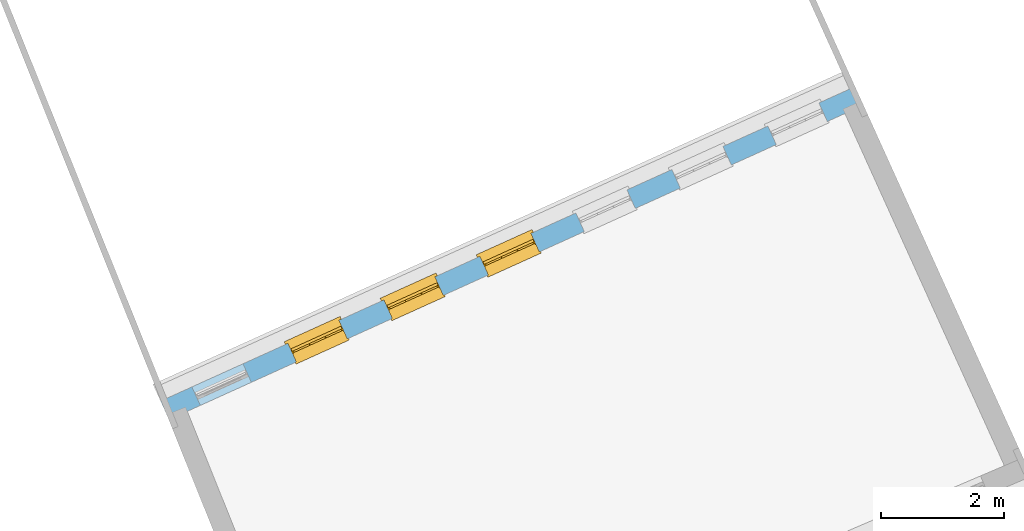
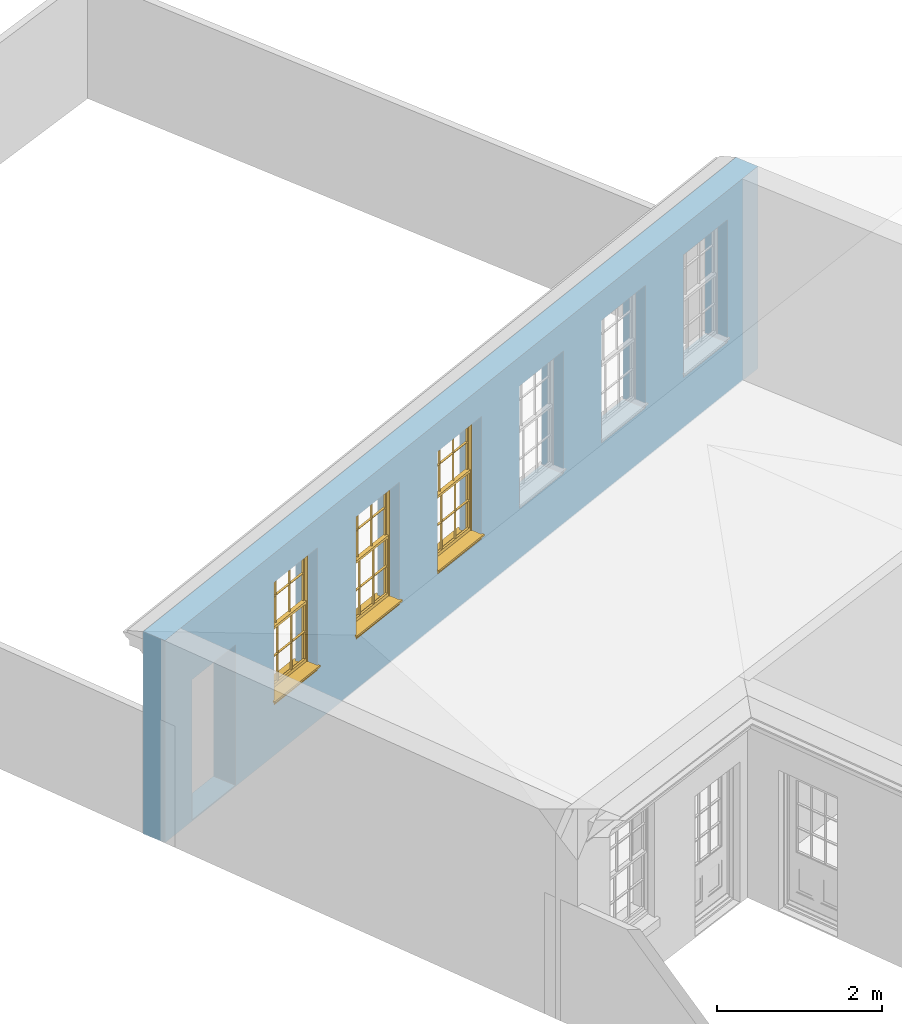
# One storey, part 16 of 19: 3 windows, 7 openings, plus 1 element that does not belong to this part.
"""IFC2X3 building model written with IfcOpenShell, lengths in metres."""

import ifcopenshell
import ifcopenshell.guid

model = None  # the IFC model being written
_history = None  # IfcOwnerHistory: only IFC2X3 demands one
_inside = {}  # id of a spatial element -> (the spatial element, [elements in it])
_under = {}  # id of a project, library or spatial element -> (it, [spatial elements below it])
_declared = {}  # id of a project -> (the project, [libraries it declares])
_typed = {}  # id of a type object -> (the type object, [elements of that type])
_made_of = {}  # id of a material, layer set ... -> (it, [elements and type objects made of it])


def new_model(schema):
    """Start an empty IFC model of exactly this schema.

    Asked for "IFC4X3", IfcOpenShell would pick the latest addendum, in which some entities
    have other attributes; the version numbers below select the first issue.
    IFC2X3 requires an IfcOwnerHistory on every rooted entity: one is made here for all.
    """
    global model, _history
    if schema == "IFC4X3":
        model = ifcopenshell.file(schema_version=(4, 3, 0, 0))
    else:
        model = ifcopenshell.file(schema=schema)
    _inside.clear()
    _under.clear()
    _declared.clear()
    _typed.clear()
    _made_of.clear()
    _history = None
    if model.schema == "IFC2X3":
        org = make("IfcOrganization", Name="unknown")
        user = make(
            "IfcPersonAndOrganization",
            ThePerson=make("IfcPerson", FamilyName="unknown"),
            TheOrganization=org,
        )
        app = make(
            "IfcApplication",
            ApplicationDeveloper=org,
            Version="unknown",
            ApplicationFullName="unknown",
            ApplicationIdentifier="unknown",
        )
        _history = make(
            "IfcOwnerHistory",
            OwningUser=user,
            OwningApplication=app,
            ChangeAction="ADDED",
            CreationDate=0,
        )
    return model


def make(cls, **values):
    """One entity of the class cls with the attributes given. An attribute that is None is left unset."""
    return model.create_entity(
        cls, **{name: value for name, value in values.items() if value is not None}
    )


def rooted(cls, **values):
    """An entity with a GlobalId (a new one), such as an element, a storey or a relation."""
    return make(cls, GlobalId=ifcopenshell.guid.new(), OwnerHistory=_history, **values)


def si_unit(unit_type, name, prefix=None):
    """IfcSIUnit, for example si_unit("LENGTHUNIT", "METRE", prefix="MILLI")."""
    return make("IfcSIUnit", UnitType=unit_type, Prefix=prefix, Name=name)


def assignment(units):
    """IfcUnitAssignment: the units of a project."""
    return None if units is None else make("IfcUnitAssignment", Units=units)


def point(xyz):
    """IfcCartesianPoint."""
    return None if xyz is None else make("IfcCartesianPoint", Coordinates=xyz)


def direction(xyz):
    """IfcDirection."""
    return None if xyz is None else make("IfcDirection", DirectionRatios=xyz)


def frame(location, z_axis=None, x_axis=None):
    """IfcAxis2Placement3D, a coordinate frame: its origin and axes. An axis left out is left unset."""
    return make(
        "IfcAxis2Placement3D",
        Location=point(location),
        Axis=direction(z_axis),
        RefDirection=direction(x_axis),
    )


def origin():
    """The frame at (0, 0, 0) with its axes left unset."""
    return frame((0.0, 0.0, 0.0))


def place(relative_to, where):
    """IfcLocalPlacement: puts the frame where relative to a parent placement (None: the world)."""
    return make(
        "IfcLocalPlacement", PlacementRelTo=relative_to, RelativePlacement=where
    )


def context(
    kind, dimensions, precision=None, world=None, true_north=None, identifier=None
):
    """IfcGeometricRepresentationContext, for example the 3D "Model" context."""
    return make(
        "IfcGeometricRepresentationContext",
        ContextIdentifier=identifier,
        ContextType=kind,
        CoordinateSpaceDimension=dimensions,
        Precision=precision,
        WorldCoordinateSystem=world,
        TrueNorth=true_north,
    )


def subcontext(parent, identifier, kind, view, scale=None):
    """IfcGeometricRepresentationSubContext, for example "Body" below "Model"."""
    return make(
        "IfcGeometricRepresentationSubContext",
        ContextIdentifier=identifier,
        ContextType=kind,
        ParentContext=parent,
        TargetScale=scale,
        TargetView=view,
    )


def project(units=None, contexts=None):
    """IfcProject with its units and contexts."""
    return rooted(
        "IfcProject",
        Name="project",
        RepresentationContexts=contexts,
        UnitsInContext=assignment(units),
    )


def spatial(cls, under=None, at=None, **own):
    """A site, building, storey or space (cls), placed at a placement, below another one or the project."""
    s = rooted(cls, ObjectPlacement=at, **own)
    if under is not None:
        _under.setdefault(under.id(), (under, []))[1].append(s)
    return s


def polyline(points):
    """IfcPolyline through the points."""
    return make("IfcPolyline", Points=[point(p) for p in points])


def outline(outer, holes=None, kind="AREA"):
    """IfcArbitraryClosedProfileDef: a profile drawn as a closed curve; with holes, ...WithVoids."""
    if holes is None:
        return make("IfcArbitraryClosedProfileDef", ProfileType=kind, OuterCurve=outer)
    return make(
        "IfcArbitraryProfileDefWithVoids",
        ProfileType=kind,
        OuterCurve=outer,
        InnerCurves=holes,
    )


def extrude(swept, where, along, depth):
    """IfcExtrudedAreaSolid: the profile swept, set in the frame where, extruded along a direction by depth."""
    return make(
        "IfcExtrudedAreaSolid",
        SweptArea=swept,
        Position=where,
        ExtrudedDirection=direction(along),
        Depth=depth,
    )


def faces_of(points, faces, orient=None, outer=None):
    """IfcFace entities. A face is a list of loops; a loop is a list of indices into points, from 0.

    orient and outer hold one flag for each loop. By default every Orientation is true, the
    first loop of a face is its IfcFaceOuterBound and the others are IfcFaceBound.
    """
    made = []
    for i, loops in enumerate(faces):
        bounds = []
        for j, loop in enumerate(loops):
            is_outer = j == 0 if outer is None else outer[i][j]
            bounds.append(
                make(
                    "IfcFaceOuterBound" if is_outer else "IfcFaceBound",
                    Bound=make("IfcPolyLoop", Polygon=[points[k] for k in loop]),
                    Orientation=True if orient is None else orient[i][j],
                )
            )
        made.append(make("IfcFace", Bounds=bounds))
    return made


def faceted_brep(points, faces, orient=None, outer=None, voids=None):
    """IfcFacetedBrep: a solid bounded by flat faces; with voids (closed shells), ...WithVoids."""
    shared = [point(p) for p in points]
    hull = make("IfcClosedShell", CfsFaces=faces_of(shared, faces, orient, outer))
    if voids is None:
        return make("IfcFacetedBrep", Outer=hull)
    return make(
        "IfcFacetedBrepWithVoids",
        Outer=hull,
        Voids=[
            make(cls, CfsFaces=faces_of(shared, fs, o, b)) for cls, fs, o, b in voids
        ],
    )


def shape(context_of_items, identifier, shape_type, items):
    """IfcShapeRepresentation: the items that make up one representation, for example the "Body"."""
    return make(
        "IfcShapeRepresentation",
        ContextOfItems=context_of_items,
        RepresentationIdentifier=identifier,
        RepresentationType=shape_type,
        Items=items,
    )


def material(Name=None, Category=None):
    """IfcMaterial."""
    return make("IfcMaterial", Name=Name, Category=Category)


def layer(
    of_material, thickness, ventilated=None, Name=None, Category=None, Priority=None
):
    """IfcMaterialLayer: one layer of a wall or slab, of a material (None: an air gap)."""
    return make(
        "IfcMaterialLayer",
        Material=of_material,
        LayerThickness=thickness,
        IsVentilated=ventilated,
        Name=Name,
        Category=Category,
        Priority=Priority,
    )


def layer_set(layers, Name=None):
    """IfcMaterialLayerSet."""
    return make("IfcMaterialLayerSet", MaterialLayers=layers, LayerSetName=Name)


def layer_usage(for_layer_set, set_direction, sense, offset, extent=None):
    """IfcMaterialLayerSetUsage: how a layer set lies in its element."""
    return make(
        "IfcMaterialLayerSetUsage",
        ForLayerSet=for_layer_set,
        LayerSetDirection=set_direction,
        DirectionSense=sense,
        OffsetFromReferenceLine=offset,
        ReferenceExtent=extent,
    )


def made_of(thing, what):
    """Note that an element or type object is made of a material, layer set ...; save() writes the relation."""
    if what is not None:
        _made_of.setdefault(what.id(), (what, []))[1].append(thing)
    return thing


def element(
    cls,
    number,
    at=None,
    inside=None,
    cuts=None,
    type_object=None,
    material=None,
    context=None,
    identifier="Body",
    shape_type=None,
    held_by="IfcProductDefinitionShape",
    body=None,
    shapes=None,
    **own,
):
    """One element of the class cls, such as IfcWall. Its Tag is "e" and its number.

    at: its placement. inside: the storey or other place that contains it. cuts: it is an
    opening in that element (IfcRelVoidsElement). A single representation is given by context,
    identifier, shape_type and body (its items); several are given by shapes. held_by: the class
    of the entity that holds the representations. save() writes the other relations.
    """
    e = rooted(cls, Tag="e%d" % number, ObjectPlacement=at, **own)
    if body is not None:
        shapes = [shape(context, identifier, shape_type, body)]
    if shapes is not None:
        e.Representation = make(held_by, Representations=shapes)
    if inside is not None:
        _inside.setdefault(inside.id(), (inside, []))[1].append(e)
    if cuts is not None:
        rooted(
            "IfcRelVoidsElement", RelatingBuildingElement=cuts, RelatedOpeningElement=e
        )
    if type_object is not None:
        _typed.setdefault(type_object.id(), (type_object, []))[1].append(e)
    return made_of(e, material)


def fill(opening, filler):
    """IfcRelFillsElement: the door or window that sits in an opening."""
    return rooted(
        "IfcRelFillsElement",
        RelatingOpeningElement=opening,
        RelatedBuildingElement=filler,
    )


def aggregate(whole, parts):
    """IfcRelAggregates: a whole, such as a stair, and the parts it consists of."""
    return rooted("IfcRelAggregates", RelatingObject=whole, RelatedObjects=parts)


def save(model, path):
    """Write the relations noted so far, then the file.

    IfcRelAggregates (storeys below a building ...), IfcRelContainedInSpatialStructure (elements
    in a storey), IfcRelDefinesByType, IfcRelAssociatesMaterial and IfcRelDeclares: one each for
    every whole, place, type object, material and project.
    """
    for whole, parts in _under.values():
        aggregate(whole, parts)
    for where, things in _inside.values():
        rooted(
            "IfcRelContainedInSpatialStructure",
            RelatedElements=things,
            RelatingStructure=where,
        )
    for kind, things in _typed.values():
        rooted("IfcRelDefinesByType", RelatedObjects=things, RelatingType=kind)
    for what, things in _made_of.values():
        rooted("IfcRelAssociatesMaterial", RelatedObjects=things, RelatingMaterial=what)
    for by, libraries in _declared.values():
        rooted("IfcRelDeclares", RelatingContext=by, RelatedDefinitions=libraries)
    model.write(path)


model = new_model("IFC2X3")

# Units and contexts
model_context = context("Model", 3, world=origin())
body_context = subcontext(model_context, "Body", "Model", "MODEL_VIEW")
ifc_project = project(units=[si_unit("PLANEANGLEUNIT", "RADIAN"), si_unit("MASSUNIT", "GRAM", prefix="KILO"), si_unit("FORCEUNIT", "NEWTON", prefix="KILO"), si_unit("LENGTHUNIT", "METRE")], contexts=[model_context])

# Site, building, storey
site_placement = place(None, origin())
site = spatial("IfcSite", under=ifc_project, at=site_placement, CompositionType="ELEMENT")
building_placement = place(None, origin())
building = spatial("IfcBuilding", under=site, at=building_placement, Name="Building plot-0", CompositionType="ELEMENT")
storey_placement = place(None, origin())
storey = spatial("IfcBuildingStorey", under=building, at=storey_placement, Name="Floor 0", CompositionType="ELEMENT", Elevation=0.0)

# Wall, openings, windows
ifc_material = material(Name="Masonry")
ifc_layer = layer(ifc_material, 0.33, ventilated=False)
ifc_layer_set = layer_set([ifc_layer], Name="My Wall")
ifc_layer_usage = layer_usage(ifc_layer_set, "AXIS2", "NEGATIVE", 0.08)
wall_placement = place(storey_placement, origin())
wall = element("IfcWallStandardCase", 1, at=wall_placement, inside=storey, material=ifc_layer_usage, Name="exterior", context=body_context, shape_type="SweptSolid", body=[
    extrude(outline(polyline([(21.5007118437475, 40.3889268355029), (21.3645733407012, 40.6895367288669), (10.0949852202286, 35.5858295970064), (10.2311237232749, 35.2852197036424), (21.5007118437475, 40.3889268355029)])), origin(), (0.0, 0.0, 1.0), 3.0),
])
opening_1_placement = place(storey_placement, frame((0.0, 0.0, 0.75)))
element("IfcOpeningElement", 2, at=opening_1_placement, cuts=wall, Name="Opening", ObjectType="Opening", context=body_context, shape_type="SweptSolid", body=[
    extrude(outline(polyline([(20.7788788084242, 40.4242907119302), (19.9499242539963, 40.048878476257), (20.0860627570426, 39.748268582893), (20.9150173114706, 40.1236808185662), (20.7788788084242, 40.4242907119302)])), origin(), (0.0, 0.0, 1.0), 1.82),
])
opening_2_placement = place(storey_placement, frame((0.0, 0.0, 0.75)))
element("IfcOpeningElement", 3, at=opening_2_placement, cuts=wall, Name="Opening", ObjectType="Opening", context=body_context, shape_type="SweptSolid", body=[
    extrude(outline(polyline([(19.2211729973563, 39.7188457415993), (18.3922184429283, 39.3434335059261), (18.5283569459746, 39.0428236125621), (19.3573115004026, 39.4182358482353), (19.2211729973563, 39.7188457415993)])), origin(), (0.0, 0.0, 1.0), 1.82),
])
opening_3_placement = place(storey_placement, frame((0.0, 0.0, 0.75)))
element("IfcOpeningElement", 4, at=opening_3_placement, cuts=wall, Name="Opening", ObjectType="Opening", context=body_context, shape_type="SweptSolid", body=[
    extrude(outline(polyline([(17.6634671862884, 39.0134007712684), (16.8345126318604, 38.6379885355952), (16.9706511349067, 38.3373786422312), (17.7996056893347, 38.7127908779044), (17.6634671862884, 39.0134007712684)])), origin(), (0.0, 0.0, 1.0), 1.82),
])
opening_4_placement = place(storey_placement, frame((0.0, 0.0, 0.75)))
opening_4 = element("IfcOpeningElement", 5, at=opening_4_placement, cuts=wall, Name="Opening", ObjectType="Opening", context=body_context, shape_type="SweptSolid", body=[
    extrude(outline(polyline([(16.1057613752204, 38.3079558009375), (15.2768068207924, 37.9325435652643), (15.4129453238388, 37.6319336719003), (16.2418998782667, 38.0073459075735), (16.1057613752204, 38.3079558009375)])), origin(), (0.0, 0.0, 1.0), 1.82),
])
opening_5_placement = place(storey_placement, frame((0.0, 0.0, 0.75)))
opening_5 = element("IfcOpeningElement", 6, at=opening_5_placement, cuts=wall, Name="Opening", ObjectType="Opening", context=body_context, shape_type="SweptSolid", body=[
    extrude(outline(polyline([(14.5480555641525, 37.6025108306066), (13.7191010097245, 37.2270985949334), (13.8552395127708, 36.9264887015694), (14.6841940671988, 37.3019009372426), (14.5480555641525, 37.6025108306066)])), origin(), (0.0, 0.0, 1.0), 1.82),
])
opening_6_placement = place(storey_placement, frame((0.0, 0.0, 0.75)))
opening_6 = element("IfcOpeningElement", 7, at=opening_6_placement, cuts=wall, Name="Opening", ObjectType="Opening", context=body_context, shape_type="SweptSolid", body=[
    extrude(outline(polyline([(12.9903497530845, 36.8970658602757), (12.1613951986565, 36.5216536246025), (12.2975337017029, 36.2210437312385), (13.1264882561308, 36.5964559669117), (12.9903497530845, 36.8970658602757)])), origin(), (0.0, 0.0, 1.0), 1.82),
])
opening_7_placement = place(storey_placement, frame((0.0, 0.0, 0.02)))
element("IfcOpeningElement", 8, at=opening_7_placement, cuts=wall, Name="Opening", ObjectType="Opening", context=body_context, shape_type="SweptSolid", body=[
    extrude(outline(polyline([(11.4326439420166, 36.1916208899448), (10.6036893875886, 35.8162086542716), (10.7398278906349, 35.5155987609077), (11.5687824450629, 35.8910109965808), (11.4326439420166, 36.1916208899448)])), origin(), (0.0, 0.0, 1.0), 2.08),
])
window_1_placement = place(storey_placement, frame((16.2088966048009, 38.0802210332375, 0.75), z_axis=(0.0, 0.0, 1.0), x_axis=(-0.82895455442797, -0.37541223567316, 0.0)))
window_1 = element("IfcWindow", 9, at=window_1_placement, inside=storey, Name="bedroom window", OverallHeight=1.82, OverallWidth=0.91, context=body_context, shape_type="Brep", held_by="IfcProductRepresentation", body=[
    faceted_brep([(0.033125, -0.105, 0.975209), (0.01, -0.105, 0.975209), (0.033125, -0.105, 1.376042), (0.876875, -0.105, 0.975209), (0.876875, -0.105, 1.376042), (0.9, -0.105, 0.975209), (0.876875, -0.105, 1.386042), (0.876875, -0.105, 1.786875), (0.9, -0.105, 1.81), (0.033125, -0.105, 1.786875), (0.033125, -0.105, 1.386042), (0.01, -0.105, 1.81), (0.876875, -0.135, 1.376042), (0.876875, -0.135, 0.975209), (0.9, -0.135, 0.937083), (0.033125, -0.135, 1.786875), (0.01, -0.135, 1.81), (0.033125, -0.135, 1.386042), (0.01, -0.135, 0.937083), (0.033125, -0.135, 0.975209), (0.033125, -0.135, 1.376042), (0.876875, -0.135, 1.786875), (0.876875, -0.135, 1.386042), (0.9, -0.135, 1.81), (0.033125, -0.105, 0.937083), (0.01, -0.105, 0.937083), (0.033125, -0.105, 0.53625), (0.876875, -0.105, 0.937083), (0.876875, -0.105, 0.53625), (0.9, -0.105, 0.937083), (0.876875, -0.105, 0.52625), (0.876875, -0.105, 0.125417), (0.9, -0.105, 0.077167), (0.033125, -0.105, 0.125417), (0.033125, -0.105, 0.52625), (0.01, -0.105, 0.077167), (-0.0425, -0.25, 0.01), (-0.0425, -0.3, 0.001667), (0.0, -0.25, 0.01), (0.9525, -0.25, 0.01), (0.91, -0.25, 0.01), (0.9525, -0.3, 0.001667), (-0.02, 0.08, 0.077167), (0.0, 0.08, 0.077167), (-0.02, 0.11, 0.077167), (0.0, -0.06, 0.077167), (0.01, -0.06, 0.077167), (0.91, -0.06, 0.077167), (0.91, 0.08, 0.077167), (0.9, -0.06, 0.077167), (0.93, 0.08, 0.077167), (0.93, 0.11, 0.077167), (0.01, -0.075, 0.975209), (0.9, -0.075, 0.975209), (0.876875, -0.075, 0.125417), (0.876875, -0.075, 0.52625), (0.9, -0.075, 0.077167), (0.876875, -0.075, 0.53625), (0.876875, -0.075, 0.937083), (0.033125, -0.075, 0.125417), (0.01, -0.075, 0.077167), (0.033125, -0.075, 0.52625), (0.033125, -0.075, 0.937083), (0.033125, -0.075, 0.53625), (-0.02, 0.08, 0.052167), (-0.02, 0.11, 0.052167), (0.93, 0.11, 0.052167), (0.93, 0.08, 0.052167), (0.91, 0.08, 0.052167), (0.0, 0.08, 0.052167), (0.91, -0.15, 0.026667), (0.0, -0.15, 0.026667), (-0.0425, -0.3, -0.123333), (0.9525, -0.3, -0.123333), (-0.0425, -0.25, -0.123333), (0.9525, -0.25, -0.123333), (0.01, -0.06, 1.81), (0.9, -0.06, 1.81), (0.0, -0.06, 1.82), (0.91, -0.06, 1.82), (0.01, -0.15, 0.077167), (0.9, -0.15, 0.077167), (0.592292, -0.105, 0.125417), (0.592292, -0.075, 0.125417), (0.317708, -0.075, 0.125417), (0.317708, -0.105, 0.125417), (0.592292, -0.105, 0.53625), (0.317708, -0.105, 0.53625), (0.317708, -0.105, 0.52625), (0.592292, -0.105, 0.52625), (0.592292, -0.075, 0.53625), (0.317708, -0.075, 0.53625), (0.592292, -0.135, 1.386042), (0.592292, -0.105, 1.386042), (0.317708, -0.105, 1.386042), (0.317708, -0.135, 1.386042), (0.317708, -0.135, 1.376042), (0.592292, -0.135, 1.376042), (0.317708, -0.105, 1.376042), (0.592292, -0.105, 1.376042), (0.602292, -0.135, 1.376042), (0.592292, -0.135, 0.975209), (0.602292, -0.135, 0.975209), (0.602292, -0.105, 0.975209), (0.592292, -0.105, 0.975209), (0.602292, -0.105, 1.376042), (0.602292, -0.075, 0.53625), (0.602292, -0.105, 0.53625), (0.317708, -0.075, 0.52625), (0.307708, -0.075, 0.125417), (0.307708, -0.075, 0.52625), (0.602292, -0.075, 0.52625), (0.602292, -0.075, 0.125417), (0.592292, -0.075, 0.52625), (0.307708, -0.075, 0.53625), (0.317708, -0.075, 0.937083), (0.307708, -0.075, 0.937083), (0.602292, -0.075, 0.937083), (0.592292, -0.075, 0.937083), (0.307708, -0.105, 0.52625), (0.307708, -0.105, 0.125417), (0.307708, -0.105, 0.53625), (0.307708, -0.105, 0.937083), (0.592292, -0.105, 0.937083), (0.317708, -0.105, 0.937083), (0.602292, -0.105, 0.937083), (0.602292, -0.105, 0.52625), (0.602292, -0.105, 0.125417), (0.307708, -0.135, 1.386042), (0.307708, -0.135, 1.376042), (0.307708, -0.135, 0.975209), (0.317708, -0.135, 0.975209), (0.317708, -0.135, 1.786875), (0.307708, -0.135, 1.786875), (0.602292, -0.135, 1.786875), (0.592292, -0.135, 1.786875), (0.602292, -0.135, 1.386042), (0.602292, -0.105, 1.386042), (0.307708, -0.105, 1.386042), (0.307708, -0.105, 1.786875), (0.317708, -0.105, 1.786875), (0.592292, -0.105, 1.786875), (0.602292, -0.105, 1.786875), (0.307708, -0.105, 1.376042), (0.317708, -0.105, 0.975209), (0.307708, -0.105, 0.975209), (0.91, -0.15, 1.82), (0.9, -0.15, 1.81), (0.01, -0.15, 1.81), (0.0, -0.15, 1.82), (0.91, -0.25, 0.0), (0.0, -0.25, 0.0), (0.91, 0.08, 0.0), (0.0, 0.08, 0.0)], [[[0, 1, 2]], [[3, 4, 5]], [[6, 7, 8]], [[9, 10, 11]], [[12, 13, 14]], [[15, 16, 17]], [[18, 19, 20]], [[21, 22, 23]], [[24, 25, 26]], [[27, 28, 29]], [[30, 31, 32]], [[33, 34, 35]], [[14, 27, 29]], [[25, 24, 18]], [[36, 37, 38]], [[39, 40, 41]], [[42, 43, 44]], [[45, 46, 43]], [[47, 48, 49]], [[50, 51, 48]], [[1, 0, 52]], [[5, 53, 3]], [[54, 55, 56]], [[57, 58, 53]], [[59, 60, 61]], [[62, 63, 52]], [[48, 43, 46, 49]], [[51, 44, 43, 48]], [[64, 42, 44, 65]], [[65, 44, 51, 66]], [[66, 51, 50, 67]], [[65, 66, 68, 69]], [[60, 56, 49, 46]], [[70, 71, 38, 40]], [[37, 41, 40, 38]], [[37, 72, 73, 41]], [[74, 75, 73, 72]], [[8, 11, 76, 77]], [[76, 78, 79, 77]], [[32, 35, 80, 81]], [[81, 80, 71, 70]], [[82, 83, 84, 85]], [[86, 87, 88, 89]], [[86, 90, 91, 87]], [[92, 93, 94, 95]], [[92, 95, 96, 97]], [[96, 98, 99, 97]], [[100, 97, 101, 102]], [[103, 104, 99, 105]], [[97, 99, 104, 101]], [[102, 103, 105, 100]], [[28, 57, 106, 107]], [[108, 84, 109, 110]], [[111, 112, 83, 113]], [[114, 110, 61, 63]], [[90, 113, 108, 91]], [[115, 91, 114, 116]], [[117, 106, 90, 118]], [[111, 106, 57, 55]], [[119, 110, 109, 120]], [[34, 61, 110, 119]], [[89, 113, 83, 82]], [[88, 108, 113, 89]], [[85, 84, 108, 88]], [[121, 114, 63, 26]], [[122, 116, 114, 121]], [[123, 118, 90, 86]], [[87, 91, 115, 124]], [[107, 106, 117, 125]], [[126, 111, 55, 30]], [[127, 112, 111, 126]], [[126, 30, 28, 107]], [[88, 119, 120, 85]], [[126, 89, 82, 127]], [[125, 123, 86, 107]], [[121, 26, 34, 119]], [[124, 122, 121, 87]], [[128, 17, 20, 129]], [[96, 129, 130, 131]], [[132, 133, 128, 95]], [[134, 135, 92, 136]], [[100, 12, 22, 136]], [[137, 6, 4, 105]], [[94, 138, 139, 140]], [[137, 93, 141, 142]], [[99, 98, 94, 93]], [[143, 2, 10, 138]], [[144, 145, 143, 98]], [[129, 143, 145, 130]], [[20, 2, 143, 129]], [[131, 144, 98, 96]], [[128, 138, 10, 17]], [[133, 139, 138, 128]], [[135, 141, 93, 92]], [[95, 94, 140, 132]], [[22, 6, 137, 136]], [[136, 137, 142, 134]], [[100, 105, 4, 12]], [[107, 86, 89, 126]], [[106, 111, 113, 90]], [[91, 108, 110, 114]], [[87, 121, 119, 88]], [[97, 100, 136, 92]], [[129, 96, 95, 128]], [[98, 143, 138, 94]], [[105, 99, 93, 137]], [[131, 101, 104, 144]], [[124, 115, 118, 123]], [[132, 140, 141, 135]], [[120, 109, 59, 33]], [[15, 9, 139, 133]], [[134, 142, 7, 21]], [[31, 54, 112, 127]], [[36, 74, 72, 37]], [[39, 41, 73, 75]], [[18, 14, 101, 131]], [[23, 16, 132, 135]], [[83, 56, 60, 84]], [[52, 53, 118, 115]], [[53, 52, 144, 104]], [[11, 8, 141, 140]], [[14, 18, 124, 123]], [[2, 1, 11, 10]], [[8, 5, 4, 6]], [[57, 53, 56, 55]], [[60, 52, 63, 61]], [[26, 25, 35, 34]], [[32, 29, 28, 30]], [[14, 23, 22, 12]], [[18, 20, 17, 16]], [[19, 0, 2, 20]], [[17, 10, 9, 15]], [[12, 4, 3, 13]], [[21, 7, 6, 22]], [[27, 58, 57, 28]], [[30, 55, 54, 31]], [[33, 59, 61, 34]], [[26, 63, 62, 24]], [[5, 8, 77, 53]], [[76, 11, 1, 52]], [[46, 45, 78, 76]], [[49, 77, 79, 47]], [[70, 146, 147, 81]], [[71, 80, 148, 149]], [[19, 130, 145, 0]], [[102, 13, 3, 103]], [[116, 122, 24, 62]], [[29, 32, 81, 14]], [[80, 35, 25, 18]], [[60, 46, 76, 52]], [[77, 49, 56, 53]], [[23, 14, 81, 147]], [[16, 148, 80, 18]], [[35, 85, 120]], [[120, 33, 35]], [[127, 82, 32]], [[32, 31, 127]], [[32, 82, 85, 35]], [[102, 101, 14]], [[14, 13, 102]], [[18, 131, 130]], [[130, 19, 18]], [[134, 21, 23]], [[23, 135, 134]], [[16, 15, 133]], [[133, 132, 16]], [[11, 140, 139]], [[139, 9, 11]], [[142, 141, 8]], [[8, 7, 142]], [[23, 147, 148, 16]], [[146, 149, 148, 147]], [[52, 115, 116]], [[116, 62, 52]], [[118, 53, 117]], [[58, 117, 53]], [[27, 125, 117, 58]], [[56, 83, 112]], [[112, 54, 56]], [[109, 84, 60]], [[60, 59, 109]], [[125, 27, 14]], [[14, 123, 125]], [[122, 124, 18]], [[18, 24, 122]], [[145, 144, 52]], [[52, 0, 145]], [[103, 3, 53]], [[53, 104, 103]], [[79, 78, 149, 146]], [[78, 45, 71, 149]], [[146, 70, 47, 79]], [[150, 75, 74, 151]], [[68, 66, 67]], [[48, 68, 67, 50]], [[69, 64, 65]], [[42, 64, 69, 43]], [[69, 68, 152, 153]], [[70, 68, 48, 47]], [[150, 152, 68, 70]], [[43, 69, 71, 45]], [[69, 153, 151, 71]], [[152, 150, 151, 153]], [[38, 151, 74, 36]], [[71, 151, 38]], [[39, 75, 150, 40]], [[40, 150, 70]]]),
])
fill(opening_4, window_1)
window_2_placement = place(storey_placement, frame((14.651190793733, 37.3747760629066, 0.75), z_axis=(0.0, 0.0, 1.0), x_axis=(-0.828954554427973, -0.375412235673167, 0.0)))
window_2 = element("IfcWindow", 10, at=window_2_placement, inside=storey, Name="bedroom window", OverallHeight=1.82, OverallWidth=0.91, context=body_context, shape_type="Brep", held_by="IfcProductRepresentation", body=[
    faceted_brep([(0.033125, -0.105, 0.975209), (0.01, -0.105, 0.975209), (0.033125, -0.105, 1.376042), (0.876875, -0.105, 0.975209), (0.876875, -0.105, 1.376042), (0.9, -0.105, 0.975209), (0.876875, -0.105, 1.386042), (0.876875, -0.105, 1.786875), (0.9, -0.105, 1.81), (0.033125, -0.105, 1.786875), (0.033125, -0.105, 1.386042), (0.01, -0.105, 1.81), (0.876875, -0.135, 1.376042), (0.876875, -0.135, 0.975209), (0.9, -0.135, 0.937083), (0.033125, -0.135, 1.786875), (0.01, -0.135, 1.81), (0.033125, -0.135, 1.386042), (0.01, -0.135, 0.937083), (0.033125, -0.135, 0.975209), (0.033125, -0.135, 1.376042), (0.876875, -0.135, 1.786875), (0.876875, -0.135, 1.386042), (0.9, -0.135, 1.81), (0.033125, -0.105, 0.937083), (0.01, -0.105, 0.937083), (0.033125, -0.105, 0.53625), (0.876875, -0.105, 0.937083), (0.876875, -0.105, 0.53625), (0.9, -0.105, 0.937083), (0.876875, -0.105, 0.52625), (0.876875, -0.105, 0.125417), (0.9, -0.105, 0.077167), (0.033125, -0.105, 0.125417), (0.033125, -0.105, 0.52625), (0.01, -0.105, 0.077167), (-0.0425, -0.25, 0.01), (-0.0425, -0.3, 0.001667), (0.0, -0.25, 0.01), (0.9525, -0.25, 0.01), (0.91, -0.25, 0.01), (0.9525, -0.3, 0.001667), (-0.02, 0.08, 0.077167), (0.0, 0.08, 0.077167), (-0.02, 0.11, 0.077167), (0.0, -0.06, 0.077167), (0.01, -0.06, 0.077167), (0.91, -0.06, 0.077167), (0.91, 0.08, 0.077167), (0.9, -0.06, 0.077167), (0.93, 0.08, 0.077167), (0.93, 0.11, 0.077167), (0.01, -0.075, 0.975209), (0.9, -0.075, 0.975209), (0.876875, -0.075, 0.125417), (0.876875, -0.075, 0.52625), (0.9, -0.075, 0.077167), (0.876875, -0.075, 0.53625), (0.876875, -0.075, 0.937083), (0.033125, -0.075, 0.125417), (0.01, -0.075, 0.077167), (0.033125, -0.075, 0.52625), (0.033125, -0.075, 0.937083), (0.033125, -0.075, 0.53625), (-0.02, 0.08, 0.052167), (-0.02, 0.11, 0.052167), (0.93, 0.11, 0.052167), (0.93, 0.08, 0.052167), (0.91, 0.08, 0.052167), (0.0, 0.08, 0.052167), (0.91, -0.15, 0.026667), (0.0, -0.15, 0.026667), (-0.0425, -0.3, -0.123333), (0.9525, -0.3, -0.123333), (-0.0425, -0.25, -0.123333), (0.9525, -0.25, -0.123333), (0.01, -0.06, 1.81), (0.9, -0.06, 1.81), (0.0, -0.06, 1.82), (0.91, -0.06, 1.82), (0.01, -0.15, 0.077167), (0.9, -0.15, 0.077167), (0.592292, -0.105, 0.125417), (0.592292, -0.075, 0.125417), (0.317708, -0.075, 0.125417), (0.317708, -0.105, 0.125417), (0.592292, -0.105, 0.53625), (0.317708, -0.105, 0.53625), (0.317708, -0.105, 0.52625), (0.592292, -0.105, 0.52625), (0.592292, -0.075, 0.53625), (0.317708, -0.075, 0.53625), (0.592292, -0.135, 1.386042), (0.592292, -0.105, 1.386042), (0.317708, -0.105, 1.386042), (0.317708, -0.135, 1.386042), (0.317708, -0.135, 1.376042), (0.592292, -0.135, 1.376042), (0.317708, -0.105, 1.376042), (0.592292, -0.105, 1.376042), (0.602292, -0.135, 1.376042), (0.592292, -0.135, 0.975209), (0.602292, -0.135, 0.975209), (0.602292, -0.105, 0.975209), (0.592292, -0.105, 0.975209), (0.602292, -0.105, 1.376042), (0.602292, -0.075, 0.53625), (0.602292, -0.105, 0.53625), (0.317708, -0.075, 0.52625), (0.307708, -0.075, 0.125417), (0.307708, -0.075, 0.52625), (0.602292, -0.075, 0.52625), (0.602292, -0.075, 0.125417), (0.592292, -0.075, 0.52625), (0.307708, -0.075, 0.53625), (0.317708, -0.075, 0.937083), (0.307708, -0.075, 0.937083), (0.602292, -0.075, 0.937083), (0.592292, -0.075, 0.937083), (0.307708, -0.105, 0.52625), (0.307708, -0.105, 0.125417), (0.307708, -0.105, 0.53625), (0.307708, -0.105, 0.937083), (0.592292, -0.105, 0.937083), (0.317708, -0.105, 0.937083), (0.602292, -0.105, 0.937083), (0.602292, -0.105, 0.52625), (0.602292, -0.105, 0.125417), (0.307708, -0.135, 1.386042), (0.307708, -0.135, 1.376042), (0.307708, -0.135, 0.975209), (0.317708, -0.135, 0.975209), (0.317708, -0.135, 1.786875), (0.307708, -0.135, 1.786875), (0.602292, -0.135, 1.786875), (0.592292, -0.135, 1.786875), (0.602292, -0.135, 1.386042), (0.602292, -0.105, 1.386042), (0.307708, -0.105, 1.386042), (0.307708, -0.105, 1.786875), (0.317708, -0.105, 1.786875), (0.592292, -0.105, 1.786875), (0.602292, -0.105, 1.786875), (0.307708, -0.105, 1.376042), (0.317708, -0.105, 0.975209), (0.307708, -0.105, 0.975209), (0.91, -0.15, 1.82), (0.9, -0.15, 1.81), (0.01, -0.15, 1.81), (0.0, -0.15, 1.82), (0.91, -0.25, 0.0), (0.0, -0.25, 0.0), (0.91, 0.08, 0.0), (0.0, 0.08, 0.0)], [[[0, 1, 2]], [[3, 4, 5]], [[6, 7, 8]], [[9, 10, 11]], [[12, 13, 14]], [[15, 16, 17]], [[18, 19, 20]], [[21, 22, 23]], [[24, 25, 26]], [[27, 28, 29]], [[30, 31, 32]], [[33, 34, 35]], [[14, 27, 29]], [[25, 24, 18]], [[36, 37, 38]], [[39, 40, 41]], [[42, 43, 44]], [[45, 46, 43]], [[47, 48, 49]], [[50, 51, 48]], [[1, 0, 52]], [[5, 53, 3]], [[54, 55, 56]], [[57, 58, 53]], [[59, 60, 61]], [[62, 63, 52]], [[48, 43, 46, 49]], [[51, 44, 43, 48]], [[64, 42, 44, 65]], [[65, 44, 51, 66]], [[66, 51, 50, 67]], [[65, 66, 68, 69]], [[60, 56, 49, 46]], [[70, 71, 38, 40]], [[37, 41, 40, 38]], [[37, 72, 73, 41]], [[74, 75, 73, 72]], [[8, 11, 76, 77]], [[76, 78, 79, 77]], [[32, 35, 80, 81]], [[81, 80, 71, 70]], [[82, 83, 84, 85]], [[86, 87, 88, 89]], [[86, 90, 91, 87]], [[92, 93, 94, 95]], [[92, 95, 96, 97]], [[96, 98, 99, 97]], [[100, 97, 101, 102]], [[103, 104, 99, 105]], [[97, 99, 104, 101]], [[102, 103, 105, 100]], [[28, 57, 106, 107]], [[108, 84, 109, 110]], [[111, 112, 83, 113]], [[114, 110, 61, 63]], [[90, 113, 108, 91]], [[115, 91, 114, 116]], [[117, 106, 90, 118]], [[111, 106, 57, 55]], [[119, 110, 109, 120]], [[34, 61, 110, 119]], [[89, 113, 83, 82]], [[88, 108, 113, 89]], [[85, 84, 108, 88]], [[121, 114, 63, 26]], [[122, 116, 114, 121]], [[123, 118, 90, 86]], [[87, 91, 115, 124]], [[107, 106, 117, 125]], [[126, 111, 55, 30]], [[127, 112, 111, 126]], [[126, 30, 28, 107]], [[88, 119, 120, 85]], [[126, 89, 82, 127]], [[125, 123, 86, 107]], [[121, 26, 34, 119]], [[124, 122, 121, 87]], [[128, 17, 20, 129]], [[96, 129, 130, 131]], [[132, 133, 128, 95]], [[134, 135, 92, 136]], [[100, 12, 22, 136]], [[137, 6, 4, 105]], [[94, 138, 139, 140]], [[137, 93, 141, 142]], [[99, 98, 94, 93]], [[143, 2, 10, 138]], [[144, 145, 143, 98]], [[129, 143, 145, 130]], [[20, 2, 143, 129]], [[131, 144, 98, 96]], [[128, 138, 10, 17]], [[133, 139, 138, 128]], [[135, 141, 93, 92]], [[95, 94, 140, 132]], [[22, 6, 137, 136]], [[136, 137, 142, 134]], [[100, 105, 4, 12]], [[107, 86, 89, 126]], [[106, 111, 113, 90]], [[91, 108, 110, 114]], [[87, 121, 119, 88]], [[97, 100, 136, 92]], [[129, 96, 95, 128]], [[98, 143, 138, 94]], [[105, 99, 93, 137]], [[131, 101, 104, 144]], [[124, 115, 118, 123]], [[132, 140, 141, 135]], [[120, 109, 59, 33]], [[15, 9, 139, 133]], [[134, 142, 7, 21]], [[31, 54, 112, 127]], [[36, 74, 72, 37]], [[39, 41, 73, 75]], [[18, 14, 101, 131]], [[23, 16, 132, 135]], [[83, 56, 60, 84]], [[52, 53, 118, 115]], [[53, 52, 144, 104]], [[11, 8, 141, 140]], [[14, 18, 124, 123]], [[2, 1, 11, 10]], [[8, 5, 4, 6]], [[57, 53, 56, 55]], [[60, 52, 63, 61]], [[26, 25, 35, 34]], [[32, 29, 28, 30]], [[14, 23, 22, 12]], [[18, 20, 17, 16]], [[19, 0, 2, 20]], [[17, 10, 9, 15]], [[12, 4, 3, 13]], [[21, 7, 6, 22]], [[27, 58, 57, 28]], [[30, 55, 54, 31]], [[33, 59, 61, 34]], [[26, 63, 62, 24]], [[5, 8, 77, 53]], [[76, 11, 1, 52]], [[46, 45, 78, 76]], [[49, 77, 79, 47]], [[70, 146, 147, 81]], [[71, 80, 148, 149]], [[19, 130, 145, 0]], [[102, 13, 3, 103]], [[116, 122, 24, 62]], [[29, 32, 81, 14]], [[80, 35, 25, 18]], [[60, 46, 76, 52]], [[77, 49, 56, 53]], [[23, 14, 81, 147]], [[16, 148, 80, 18]], [[35, 85, 120]], [[120, 33, 35]], [[127, 82, 32]], [[32, 31, 127]], [[32, 82, 85, 35]], [[102, 101, 14]], [[14, 13, 102]], [[18, 131, 130]], [[130, 19, 18]], [[134, 21, 23]], [[23, 135, 134]], [[16, 15, 133]], [[133, 132, 16]], [[11, 140, 139]], [[139, 9, 11]], [[142, 141, 8]], [[8, 7, 142]], [[23, 147, 148, 16]], [[146, 149, 148, 147]], [[52, 115, 116]], [[116, 62, 52]], [[118, 53, 117]], [[58, 117, 53]], [[27, 125, 117, 58]], [[56, 83, 112]], [[112, 54, 56]], [[109, 84, 60]], [[60, 59, 109]], [[125, 27, 14]], [[14, 123, 125]], [[122, 124, 18]], [[18, 24, 122]], [[145, 144, 52]], [[52, 0, 145]], [[103, 3, 53]], [[53, 104, 103]], [[79, 78, 149, 146]], [[78, 45, 71, 149]], [[146, 70, 47, 79]], [[150, 75, 74, 151]], [[68, 66, 67]], [[48, 68, 67, 50]], [[69, 64, 65]], [[42, 64, 69, 43]], [[69, 68, 152, 153]], [[70, 68, 48, 47]], [[150, 152, 68, 70]], [[43, 69, 71, 45]], [[69, 153, 151, 71]], [[152, 150, 151, 153]], [[38, 151, 74, 36]], [[71, 151, 38]], [[39, 75, 150, 40]], [[40, 150, 70]]]),
])
fill(opening_5, window_2)
window_3_placement = place(storey_placement, frame((13.0934849826651, 36.6693310925757, 0.75), z_axis=(0.0, 0.0, 1.0), x_axis=(-0.828954554427972, -0.375412235673167, 0.0)))
window_3 = element("IfcWindow", 11, at=window_3_placement, inside=storey, Name="bedroom window", OverallHeight=1.82, OverallWidth=0.91, context=body_context, shape_type="Brep", held_by="IfcProductRepresentation", body=[
    faceted_brep([(0.033125, -0.105, 0.975209), (0.01, -0.105, 0.975209), (0.033125, -0.105, 1.376042), (0.876875, -0.105, 0.975209), (0.876875, -0.105, 1.376042), (0.9, -0.105, 0.975209), (0.876875, -0.105, 1.386042), (0.876875, -0.105, 1.786875), (0.9, -0.105, 1.81), (0.033125, -0.105, 1.786875), (0.033125, -0.105, 1.386042), (0.01, -0.105, 1.81), (0.876875, -0.135, 1.376042), (0.876875, -0.135, 0.975209), (0.9, -0.135, 0.937083), (0.033125, -0.135, 1.786875), (0.01, -0.135, 1.81), (0.033125, -0.135, 1.386042), (0.01, -0.135, 0.937083), (0.033125, -0.135, 0.975209), (0.033125, -0.135, 1.376042), (0.876875, -0.135, 1.786875), (0.876875, -0.135, 1.386042), (0.9, -0.135, 1.81), (0.033125, -0.105, 0.937083), (0.01, -0.105, 0.937083), (0.033125, -0.105, 0.53625), (0.876875, -0.105, 0.937083), (0.876875, -0.105, 0.53625), (0.9, -0.105, 0.937083), (0.876875, -0.105, 0.52625), (0.876875, -0.105, 0.125417), (0.9, -0.105, 0.077167), (0.033125, -0.105, 0.125417), (0.033125, -0.105, 0.52625), (0.01, -0.105, 0.077167), (-0.0425, -0.25, 0.01), (-0.0425, -0.3, 0.001667), (0.0, -0.25, 0.01), (0.9525, -0.25, 0.01), (0.91, -0.25, 0.01), (0.9525, -0.3, 0.001667), (-0.02, 0.08, 0.077167), (0.0, 0.08, 0.077167), (-0.02, 0.11, 0.077167), (0.0, -0.06, 0.077167), (0.01, -0.06, 0.077167), (0.91, -0.06, 0.077167), (0.91, 0.08, 0.077167), (0.9, -0.06, 0.077167), (0.93, 0.08, 0.077167), (0.93, 0.11, 0.077167), (0.01, -0.075, 0.975209), (0.9, -0.075, 0.975209), (0.876875, -0.075, 0.125417), (0.876875, -0.075, 0.52625), (0.9, -0.075, 0.077167), (0.876875, -0.075, 0.53625), (0.876875, -0.075, 0.937083), (0.033125, -0.075, 0.125417), (0.01, -0.075, 0.077167), (0.033125, -0.075, 0.52625), (0.033125, -0.075, 0.937083), (0.033125, -0.075, 0.53625), (-0.02, 0.08, 0.052167), (-0.02, 0.11, 0.052167), (0.93, 0.11, 0.052167), (0.93, 0.08, 0.052167), (0.91, 0.08, 0.052167), (0.0, 0.08, 0.052167), (0.91, -0.15, 0.026667), (0.0, -0.15, 0.026667), (-0.0425, -0.3, -0.123333), (0.9525, -0.3, -0.123333), (-0.0425, -0.25, -0.123333), (0.9525, -0.25, -0.123333), (0.01, -0.06, 1.81), (0.9, -0.06, 1.81), (0.0, -0.06, 1.82), (0.91, -0.06, 1.82), (0.01, -0.15, 0.077167), (0.9, -0.15, 0.077167), (0.592292, -0.105, 0.125417), (0.592292, -0.075, 0.125417), (0.317708, -0.075, 0.125417), (0.317708, -0.105, 0.125417), (0.592292, -0.105, 0.53625), (0.317708, -0.105, 0.53625), (0.317708, -0.105, 0.52625), (0.592292, -0.105, 0.52625), (0.592292, -0.075, 0.53625), (0.317708, -0.075, 0.53625), (0.592292, -0.135, 1.386042), (0.592292, -0.105, 1.386042), (0.317708, -0.105, 1.386042), (0.317708, -0.135, 1.386042), (0.317708, -0.135, 1.376042), (0.592292, -0.135, 1.376042), (0.317708, -0.105, 1.376042), (0.592292, -0.105, 1.376042), (0.602292, -0.135, 1.376042), (0.592292, -0.135, 0.975209), (0.602292, -0.135, 0.975209), (0.602292, -0.105, 0.975209), (0.592292, -0.105, 0.975209), (0.602292, -0.105, 1.376042), (0.602292, -0.075, 0.53625), (0.602292, -0.105, 0.53625), (0.317708, -0.075, 0.52625), (0.307708, -0.075, 0.125417), (0.307708, -0.075, 0.52625), (0.602292, -0.075, 0.52625), (0.602292, -0.075, 0.125417), (0.592292, -0.075, 0.52625), (0.307708, -0.075, 0.53625), (0.317708, -0.075, 0.937083), (0.307708, -0.075, 0.937083), (0.602292, -0.075, 0.937083), (0.592292, -0.075, 0.937083), (0.307708, -0.105, 0.52625), (0.307708, -0.105, 0.125417), (0.307708, -0.105, 0.53625), (0.307708, -0.105, 0.937083), (0.592292, -0.105, 0.937083), (0.317708, -0.105, 0.937083), (0.602292, -0.105, 0.937083), (0.602292, -0.105, 0.52625), (0.602292, -0.105, 0.125417), (0.307708, -0.135, 1.386042), (0.307708, -0.135, 1.376042), (0.307708, -0.135, 0.975209), (0.317708, -0.135, 0.975209), (0.317708, -0.135, 1.786875), (0.307708, -0.135, 1.786875), (0.602292, -0.135, 1.786875), (0.592292, -0.135, 1.786875), (0.602292, -0.135, 1.386042), (0.602292, -0.105, 1.386042), (0.307708, -0.105, 1.386042), (0.307708, -0.105, 1.786875), (0.317708, -0.105, 1.786875), (0.592292, -0.105, 1.786875), (0.602292, -0.105, 1.786875), (0.307708, -0.105, 1.376042), (0.317708, -0.105, 0.975209), (0.307708, -0.105, 0.975209), (0.91, -0.15, 1.82), (0.9, -0.15, 1.81), (0.01, -0.15, 1.81), (0.0, -0.15, 1.82), (0.91, -0.25, 0.0), (0.0, -0.25, 0.0), (0.91, 0.08, 0.0), (0.0, 0.08, 0.0)], [[[0, 1, 2]], [[3, 4, 5]], [[6, 7, 8]], [[9, 10, 11]], [[12, 13, 14]], [[15, 16, 17]], [[18, 19, 20]], [[21, 22, 23]], [[24, 25, 26]], [[27, 28, 29]], [[30, 31, 32]], [[33, 34, 35]], [[14, 27, 29]], [[25, 24, 18]], [[36, 37, 38]], [[39, 40, 41]], [[42, 43, 44]], [[45, 46, 43]], [[47, 48, 49]], [[50, 51, 48]], [[1, 0, 52]], [[5, 53, 3]], [[54, 55, 56]], [[57, 58, 53]], [[59, 60, 61]], [[62, 63, 52]], [[48, 43, 46, 49]], [[51, 44, 43, 48]], [[64, 42, 44, 65]], [[65, 44, 51, 66]], [[66, 51, 50, 67]], [[65, 66, 68, 69]], [[60, 56, 49, 46]], [[70, 71, 38, 40]], [[37, 41, 40, 38]], [[37, 72, 73, 41]], [[74, 75, 73, 72]], [[8, 11, 76, 77]], [[76, 78, 79, 77]], [[32, 35, 80, 81]], [[81, 80, 71, 70]], [[82, 83, 84, 85]], [[86, 87, 88, 89]], [[86, 90, 91, 87]], [[92, 93, 94, 95]], [[92, 95, 96, 97]], [[96, 98, 99, 97]], [[100, 97, 101, 102]], [[103, 104, 99, 105]], [[97, 99, 104, 101]], [[102, 103, 105, 100]], [[28, 57, 106, 107]], [[108, 84, 109, 110]], [[111, 112, 83, 113]], [[114, 110, 61, 63]], [[90, 113, 108, 91]], [[115, 91, 114, 116]], [[117, 106, 90, 118]], [[111, 106, 57, 55]], [[119, 110, 109, 120]], [[34, 61, 110, 119]], [[89, 113, 83, 82]], [[88, 108, 113, 89]], [[85, 84, 108, 88]], [[121, 114, 63, 26]], [[122, 116, 114, 121]], [[123, 118, 90, 86]], [[87, 91, 115, 124]], [[107, 106, 117, 125]], [[126, 111, 55, 30]], [[127, 112, 111, 126]], [[126, 30, 28, 107]], [[88, 119, 120, 85]], [[126, 89, 82, 127]], [[125, 123, 86, 107]], [[121, 26, 34, 119]], [[124, 122, 121, 87]], [[128, 17, 20, 129]], [[96, 129, 130, 131]], [[132, 133, 128, 95]], [[134, 135, 92, 136]], [[100, 12, 22, 136]], [[137, 6, 4, 105]], [[94, 138, 139, 140]], [[137, 93, 141, 142]], [[99, 98, 94, 93]], [[143, 2, 10, 138]], [[144, 145, 143, 98]], [[129, 143, 145, 130]], [[20, 2, 143, 129]], [[131, 144, 98, 96]], [[128, 138, 10, 17]], [[133, 139, 138, 128]], [[135, 141, 93, 92]], [[95, 94, 140, 132]], [[22, 6, 137, 136]], [[136, 137, 142, 134]], [[100, 105, 4, 12]], [[107, 86, 89, 126]], [[106, 111, 113, 90]], [[91, 108, 110, 114]], [[87, 121, 119, 88]], [[97, 100, 136, 92]], [[129, 96, 95, 128]], [[98, 143, 138, 94]], [[105, 99, 93, 137]], [[131, 101, 104, 144]], [[124, 115, 118, 123]], [[132, 140, 141, 135]], [[120, 109, 59, 33]], [[15, 9, 139, 133]], [[134, 142, 7, 21]], [[31, 54, 112, 127]], [[36, 74, 72, 37]], [[39, 41, 73, 75]], [[18, 14, 101, 131]], [[23, 16, 132, 135]], [[83, 56, 60, 84]], [[52, 53, 118, 115]], [[53, 52, 144, 104]], [[11, 8, 141, 140]], [[14, 18, 124, 123]], [[2, 1, 11, 10]], [[8, 5, 4, 6]], [[57, 53, 56, 55]], [[60, 52, 63, 61]], [[26, 25, 35, 34]], [[32, 29, 28, 30]], [[14, 23, 22, 12]], [[18, 20, 17, 16]], [[19, 0, 2, 20]], [[17, 10, 9, 15]], [[12, 4, 3, 13]], [[21, 7, 6, 22]], [[27, 58, 57, 28]], [[30, 55, 54, 31]], [[33, 59, 61, 34]], [[26, 63, 62, 24]], [[5, 8, 77, 53]], [[76, 11, 1, 52]], [[46, 45, 78, 76]], [[49, 77, 79, 47]], [[70, 146, 147, 81]], [[71, 80, 148, 149]], [[19, 130, 145, 0]], [[102, 13, 3, 103]], [[116, 122, 24, 62]], [[29, 32, 81, 14]], [[80, 35, 25, 18]], [[60, 46, 76, 52]], [[77, 49, 56, 53]], [[23, 14, 81, 147]], [[16, 148, 80, 18]], [[35, 85, 120]], [[120, 33, 35]], [[127, 82, 32]], [[32, 31, 127]], [[32, 82, 85, 35]], [[102, 101, 14]], [[14, 13, 102]], [[18, 131, 130]], [[130, 19, 18]], [[134, 21, 23]], [[23, 135, 134]], [[16, 15, 133]], [[133, 132, 16]], [[11, 140, 139]], [[139, 9, 11]], [[142, 141, 8]], [[8, 7, 142]], [[23, 147, 148, 16]], [[146, 149, 148, 147]], [[52, 115, 116]], [[116, 62, 52]], [[118, 53, 117]], [[58, 117, 53]], [[27, 125, 117, 58]], [[56, 83, 112]], [[112, 54, 56]], [[109, 84, 60]], [[60, 59, 109]], [[125, 27, 14]], [[14, 123, 125]], [[122, 124, 18]], [[18, 24, 122]], [[145, 144, 52]], [[52, 0, 145]], [[103, 3, 53]], [[53, 104, 103]], [[79, 78, 149, 146]], [[78, 45, 71, 149]], [[146, 70, 47, 79]], [[150, 75, 74, 151]], [[68, 66, 67]], [[48, 68, 67, 50]], [[69, 64, 65]], [[42, 64, 69, 43]], [[69, 68, 152, 153]], [[70, 68, 48, 47]], [[150, 152, 68, 70]], [[43, 69, 71, 45]], [[69, 153, 151, 71]], [[152, 150, 151, 153]], [[38, 151, 74, 36]], [[71, 151, 38]], [[39, 75, 150, 40]], [[40, 150, 70]]]),
])
fill(opening_6, window_3)

save(model, "model.ifc")
